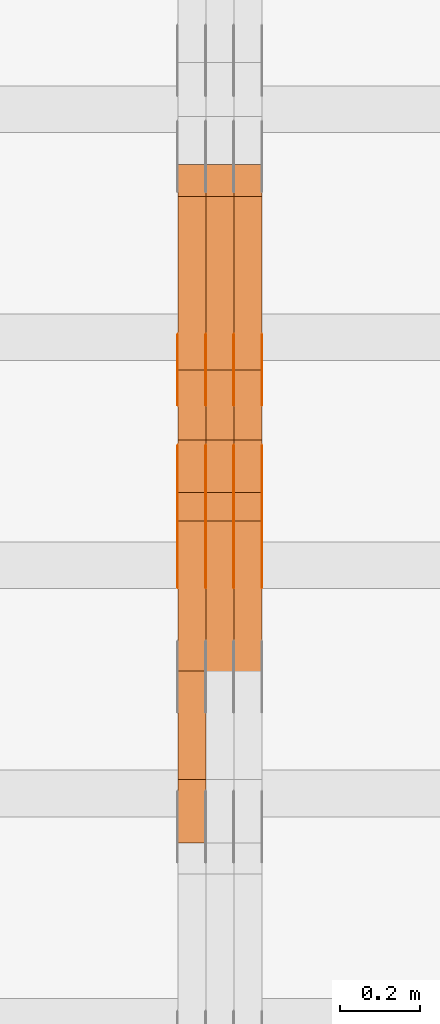
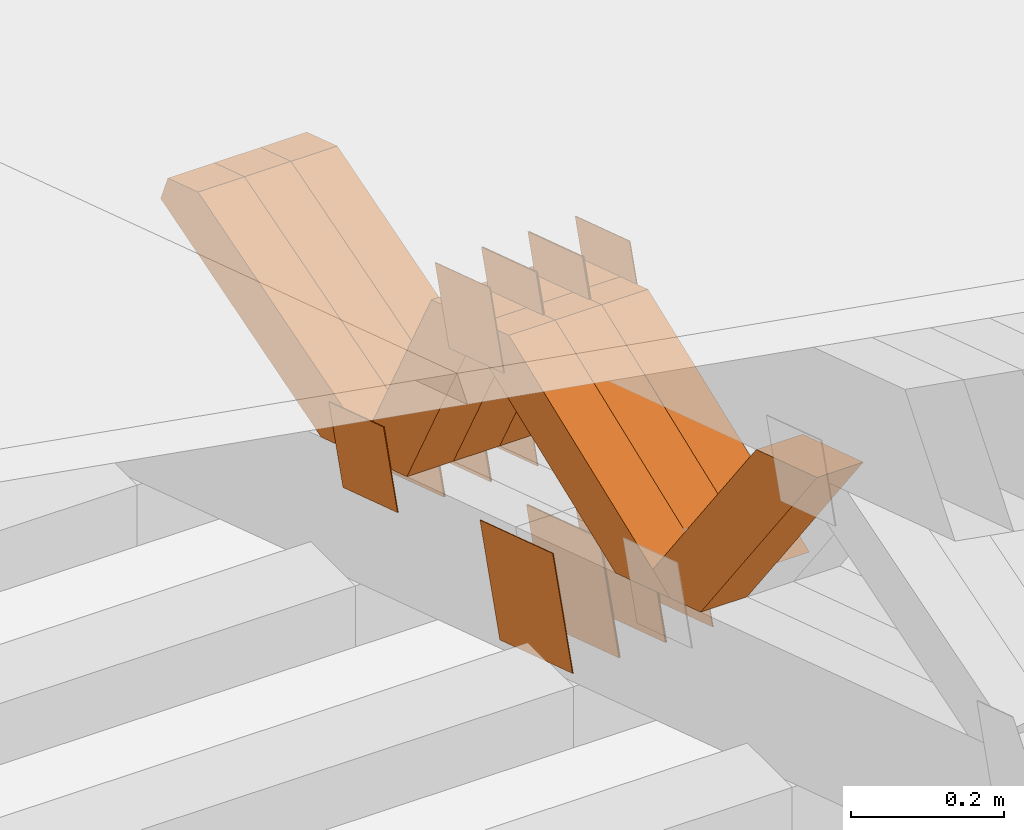
# One storey, part 233 of 385: 28 proxies.
"""IFC2X3 building model written with IfcOpenShell, lengths in millimetres."""

from ifc_helpers import new_model, entity, si_unit, converted_unit, derived_unit, direction, frame, origin, place, context, subcontext, project, spatial, polyline, outline, extrude, source, transform, mapped, material, type_object, type_shapes, element, save


model = new_model("IFC2X3")

# Units and contexts
model_context = context("Model", 3, precision=0.01, world=origin(), true_north=direction((6.12303176911189e-17, 1.0)))
body_context = subcontext(model_context, "Body", "Model", "MODEL_VIEW")
ifc_project = project(units=[si_unit("LENGTHUNIT", "METRE", prefix="MILLI"), si_unit("AREAUNIT", "SQUARE_METRE"), si_unit("VOLUMEUNIT", "CUBIC_METRE"), converted_unit("PLANEANGLEUNIT", "DEGREE", entity("IfcRatioMeasure", 0.0174532925199433), si_unit("PLANEANGLEUNIT", "RADIAN"), dimensions=[0, 0, 0, 0, 0, 0, 0]), si_unit("MASSUNIT", "GRAM", prefix="KILO"), derived_unit("MASSDENSITYUNIT", [(si_unit("MASSUNIT", "GRAM", prefix="KILO"), 1), (si_unit("LENGTHUNIT", "METRE"), -3)]), si_unit("TIMEUNIT", "SECOND"), si_unit("FREQUENCYUNIT", "HERTZ"), si_unit("THERMODYNAMICTEMPERATUREUNIT", "DEGREE_CELSIUS"), derived_unit("THERMALTRANSMITTANCEUNIT", [(si_unit("MASSUNIT", "GRAM", prefix="KILO"), 1), (si_unit("THERMODYNAMICTEMPERATUREUNIT", "KELVIN"), -1), (si_unit("TIMEUNIT", "SECOND"), -3)]), derived_unit("VOLUMETRICFLOWRATEUNIT", [(si_unit("LENGTHUNIT", "METRE"), 3), (si_unit("TIMEUNIT", "SECOND"), -1)]), si_unit("ELECTRICCURRENTUNIT", "AMPERE"), si_unit("ELECTRICVOLTAGEUNIT", "VOLT"), si_unit("POWERUNIT", "WATT"), si_unit("FORCEUNIT", "NEWTON", prefix="KILO"), si_unit("ILLUMINANCEUNIT", "LUX"), si_unit("LUMINOUSFLUXUNIT", "LUMEN"), si_unit("LUMINOUSINTENSITYUNIT", "CANDELA"), derived_unit("USERDEFINED", [(si_unit("MASSUNIT", "GRAM", prefix="KILO"), -1), (si_unit("LENGTHUNIT", "METRE"), -2), (si_unit("TIMEUNIT", "SECOND"), 3), (si_unit("LUMINOUSFLUXUNIT", "LUMEN"), 1)]), derived_unit("LINEARVELOCITYUNIT", [(si_unit("LENGTHUNIT", "METRE"), 1), (si_unit("TIMEUNIT", "SECOND"), -1)]), si_unit("PRESSUREUNIT", "PASCAL"), derived_unit("USERDEFINED", [(si_unit("LENGTHUNIT", "METRE"), -2), (si_unit("MASSUNIT", "GRAM", prefix="KILO"), 1), (si_unit("TIMEUNIT", "SECOND"), -2)])], contexts=[model_context])

# Site, building, storey
site_placement = place(None, origin())
site = spatial("IfcSite", under=ifc_project, at=site_placement, CompositionType="ELEMENT")
building_placement = place(site_placement, origin())
building = spatial("IfcBuilding", under=site, at=building_placement, CompositionType="ELEMENT")
storey_placement = place(building_placement, origin())
storey = spatial("IfcBuildingStorey", under=building, at=storey_placement, Name="Default", CompositionType="ELEMENT", Elevation=0.0)

# Proxies
ifc_material_1 = material(Name="IfcSurfaceStyle #378564")
building_element_proxy_type_1 = type_object("IfcBuildingElementProxyType", PredefinedType="NOTDEFINED", material=ifc_material_1)
shared_shape_1 = source(origin(), body_context, "Body", "SweptSolid", [
    extrude(outline(polyline([(-74.9998794200123, -59.999984515643), (74.9998565677174, -59.999984515643), (74.9998794200123, 59.999984515643), (-74.9998565677174, 59.999984515643), (-74.9998794200123, -59.999984515643)])), frame((75.0000769557496, 60.0000596852268, 0.0), z_axis=(0.0, 0.0, 1.0), x_axis=(-1.0, 0.0, 0.0)), (0.0, 0.0, 1.0), 1.3),
])
type_shapes(building_element_proxy_type_1, [shared_shape_1])
proxy_1_placement = place(building_placement, frame((30386.3, 22649.3668870864, 1282.62115477841), z_axis=(-1.0, 0.0, 0.0), x_axis=(0.0, -0.951056516295124, 0.309016994375039)))
element("IfcBuildingElementProxy", 1, at=proxy_1_placement, inside=storey, type_object=building_element_proxy_type_1, material=ifc_material_1, context=body_context, shape_type="MappedRepresentation", body=[
    mapped(shared_shape_1, transform((0.0, 0.0, 0.0), scale=1.0)),
])
ifc_material_2 = material(Name="IfcSurfaceStyle #378507")
building_element_proxy_type_2 = type_object("IfcBuildingElementProxyType", PredefinedType="NOTDEFINED", material=ifc_material_2)
shared_shape_2 = source(origin(), body_context, "Body", "SweptSolid", [
    extrude(outline(polyline([(-74.9998794200123, -59.999984515643), (74.9998565677174, -59.999984515643), (74.9998794200123, 59.999984515643), (-74.9998565677174, 59.999984515643), (-74.9998794200123, -59.999984515643)])), frame((75.0000769557496, 60.0000596852268, 0.0), z_axis=(0.0, 0.0, 1.0), x_axis=(-1.0, 0.0, 0.0)), (0.0, 0.0, 1.0), 1.3),
])
type_shapes(building_element_proxy_type_2, [shared_shape_2])
proxy_2_placement = place(building_placement, frame((30315.0, 22649.3668870864, 1282.62115477841), z_axis=(-1.0, 0.0, 0.0), x_axis=(0.0, -0.951056516295124, 0.309016994375039)))
element("IfcBuildingElementProxy", 2, at=proxy_2_placement, inside=storey, type_object=building_element_proxy_type_2, material=ifc_material_2, context=body_context, shape_type="MappedRepresentation", body=[
    mapped(shared_shape_2, transform((0.0, 0.0, 0.0), scale=1.0)),
])
ifc_material_3 = material(Name="IfcSurfaceStyle #378450")
building_element_proxy_type_3 = type_object("IfcBuildingElementProxyType", PredefinedType="NOTDEFINED", material=ifc_material_3)
shared_shape_3 = source(origin(), body_context, "Body", "SweptSolid", [
    extrude(outline(polyline([(-74.9998794200123, -59.999984515643), (74.9998565677174, -59.999984515643), (74.9998794200123, 59.999984515643), (-74.9998565677174, 59.999984515643), (-74.9998794200123, -59.999984515643)])), frame((75.0000769557496, 60.0000596852268, 0.0), z_axis=(0.0, 0.0, 1.0), x_axis=(-1.0, 0.0, 0.0)), (0.0, 0.0, 1.0), 1.3),
])
type_shapes(building_element_proxy_type_3, [shared_shape_3])
proxy_3_placement = place(building_placement, frame((30316.3, 22649.3668870864, 1282.62115477841), z_axis=(-1.0, 0.0, 0.0), x_axis=(0.0, -0.951056516295124, 0.309016994375039)))
element("IfcBuildingElementProxy", 3, at=proxy_3_placement, inside=storey, type_object=building_element_proxy_type_3, material=ifc_material_3, context=body_context, shape_type="MappedRepresentation", body=[
    mapped(shared_shape_3, transform((0.0, 0.0, 0.0), scale=1.0)),
])
ifc_material_4 = material(Name="IfcSurfaceStyle #378393")
building_element_proxy_type_4 = type_object("IfcBuildingElementProxyType", PredefinedType="NOTDEFINED", material=ifc_material_4)
shared_shape_4 = source(origin(), body_context, "Body", "SweptSolid", [
    extrude(outline(polyline([(-74.9998794200123, -59.999984515643), (74.9998565677174, -59.999984515643), (74.9998794200123, 59.999984515643), (-74.9998565677174, 59.999984515643), (-74.9998794200123, -59.999984515643)])), frame((75.0000769557496, 60.0000596852268, 0.0), z_axis=(0.0, 0.0, 1.0), x_axis=(-1.0, 0.0, 0.0)), (0.0, 0.0, 1.0), 1.29999999999999),
])
type_shapes(building_element_proxy_type_4, [shared_shape_4])
proxy_4_placement = place(building_placement, frame((30245.0, 22649.3668870864, 1282.62115477841), z_axis=(-1.0, 0.0, 0.0), x_axis=(0.0, -0.951056516295124, 0.309016994375039)))
element("IfcBuildingElementProxy", 4, at=proxy_4_placement, inside=storey, type_object=building_element_proxy_type_4, material=ifc_material_4, context=body_context, shape_type="MappedRepresentation", body=[
    mapped(shared_shape_4, transform((0.0, 0.0, 0.0), scale=1.0)),
])
ifc_material_5 = material(Name="IfcSurfaceStyle #378336")
building_element_proxy_type_5 = type_object("IfcBuildingElementProxyType", PredefinedType="NOTDEFINED", material=ifc_material_5)
shared_shape_5 = source(origin(), body_context, "Body", "SweptSolid", [
    extrude(outline(polyline([(-74.9998794200123, -59.999984515643), (74.9998565677174, -59.999984515643), (74.9998794200123, 59.999984515643), (-74.9998565677174, 59.999984515643), (-74.9998794200123, -59.999984515643)])), frame((75.0000769557496, 60.0000596852268, 0.0), z_axis=(0.0, 0.0, 1.0), x_axis=(-1.0, 0.0, 0.0)), (0.0, 0.0, 1.0), 1.29999999999999),
])
type_shapes(building_element_proxy_type_5, [shared_shape_5])
proxy_5_placement = place(building_placement, frame((30246.3, 22649.3668870864, 1282.62115477841), z_axis=(-1.0, 0.0, 0.0), x_axis=(0.0, -0.951056516295124, 0.309016994375039)))
element("IfcBuildingElementProxy", 5, at=proxy_5_placement, inside=storey, type_object=building_element_proxy_type_5, material=ifc_material_5, context=body_context, shape_type="MappedRepresentation", body=[
    mapped(shared_shape_5, transform((0.0, 0.0, 0.0), scale=1.0)),
])
ifc_material_6 = material(Name="IfcSurfaceStyle #378279")
building_element_proxy_type_6 = type_object("IfcBuildingElementProxyType", PredefinedType="NOTDEFINED", material=ifc_material_6)
shared_shape_6 = source(origin(), body_context, "Body", "SweptSolid", [
    extrude(outline(polyline([(-74.9998794200123, -59.999984515643), (74.9998565677174, -59.999984515643), (74.9998794200123, 59.999984515643), (-74.9998565677174, 59.999984515643), (-74.9998794200123, -59.999984515643)])), frame((75.0000769557496, 60.0000596852268, 0.0), z_axis=(0.0, 0.0, 1.0), x_axis=(-1.0, 0.0, 0.0)), (0.0, 0.0, 1.0), 1.29999999999999),
])
type_shapes(building_element_proxy_type_6, [shared_shape_6])
proxy_6_placement = place(building_placement, frame((30175.0, 22649.3668870864, 1282.62115477841), z_axis=(-1.0, 0.0, 0.0), x_axis=(0.0, -0.951056516295124, 0.309016994375039)))
element("IfcBuildingElementProxy", 6, at=proxy_6_placement, inside=storey, type_object=building_element_proxy_type_6, material=ifc_material_6, context=body_context, shape_type="MappedRepresentation", body=[
    mapped(shared_shape_6, transform((0.0, 0.0, 0.0), scale=1.0)),
])
ifc_material_7 = material(Name="IfcSurfaceStyle #377880")
building_element_proxy_type_7 = type_object("IfcBuildingElementProxyType", PredefinedType="NOTDEFINED", material=ifc_material_7)
shared_shape_7 = source(origin(), body_context, "Body", "SweptSolid", [
    extrude(outline(polyline([(-99.9999579276585, -84.0000593595837), (100.000141865112, -84.0000593595837), (99.9999579276589, 84.0000593595837), (-100.000141865112, 84.0000593595837), (-99.9999579276585, -84.0000593595837)])), frame((100.000141865112, 84.0000593595837, 0.0), z_axis=(0.0, 0.0, 1.0), x_axis=(-1.0, 0.0, 0.0)), (0.0, 0.0, 1.0), 1.3),
])
type_shapes(building_element_proxy_type_7, [shared_shape_7])
proxy_7_placement = place(building_placement, frame((30386.3, 22239.7296395088, 1287.96775368191), z_axis=(-1.0, 0.0, 0.0), x_axis=(0.0, -0.951056516295124, 0.309016994375039)))
element("IfcBuildingElementProxy", 7, at=proxy_7_placement, inside=storey, type_object=building_element_proxy_type_7, material=ifc_material_7, context=body_context, shape_type="MappedRepresentation", body=[
    mapped(shared_shape_7, transform((0.0, 0.0, 0.0), scale=1.0)),
])
ifc_material_8 = material(Name="IfcSurfaceStyle #377823")
building_element_proxy_type_8 = type_object("IfcBuildingElementProxyType", PredefinedType="NOTDEFINED", material=ifc_material_8)
shared_shape_8 = source(origin(), body_context, "Body", "SweptSolid", [
    extrude(outline(polyline([(-99.9999579276585, -84.0000593595837), (100.000141865112, -84.0000593595837), (99.9999579276589, 84.0000593595837), (-100.000141865112, 84.0000593595837), (-99.9999579276585, -84.0000593595837)])), frame((100.000141865112, 84.0000593595837, 0.0), z_axis=(0.0, 0.0, 1.0), x_axis=(-1.0, 0.0, 0.0)), (0.0, 0.0, 1.0), 1.3),
])
type_shapes(building_element_proxy_type_8, [shared_shape_8])
proxy_8_placement = place(building_placement, frame((30315.0, 22239.7296395088, 1287.96775368191), z_axis=(-1.0, 0.0, 0.0), x_axis=(0.0, -0.951056516295124, 0.309016994375039)))
element("IfcBuildingElementProxy", 8, at=proxy_8_placement, inside=storey, type_object=building_element_proxy_type_8, material=ifc_material_8, context=body_context, shape_type="MappedRepresentation", body=[
    mapped(shared_shape_8, transform((0.0, 0.0, 0.0), scale=1.0)),
])
ifc_material_9 = material(Name="IfcSurfaceStyle #377766")
building_element_proxy_type_9 = type_object("IfcBuildingElementProxyType", PredefinedType="NOTDEFINED", material=ifc_material_9)
shared_shape_9 = source(origin(), body_context, "Body", "SweptSolid", [
    extrude(outline(polyline([(-99.9999579276585, -84.0000593595837), (100.000141865112, -84.0000593595837), (99.9999579276589, 84.0000593595837), (-100.000141865112, 84.0000593595837), (-99.9999579276585, -84.0000593595837)])), frame((100.000141865112, 84.0000593595837, 0.0), z_axis=(0.0, 0.0, 1.0), x_axis=(-1.0, 0.0, 0.0)), (0.0, 0.0, 1.0), 1.3),
])
type_shapes(building_element_proxy_type_9, [shared_shape_9])
proxy_9_placement = place(building_placement, frame((30316.3, 22239.7296395088, 1287.96775368191), z_axis=(-1.0, 0.0, 0.0), x_axis=(0.0, -0.951056516295124, 0.309016994375039)))
element("IfcBuildingElementProxy", 9, at=proxy_9_placement, inside=storey, type_object=building_element_proxy_type_9, material=ifc_material_9, context=body_context, shape_type="MappedRepresentation", body=[
    mapped(shared_shape_9, transform((0.0, 0.0, 0.0), scale=1.0)),
])
ifc_material_10 = material(Name="IfcSurfaceStyle #377709")
building_element_proxy_type_10 = type_object("IfcBuildingElementProxyType", PredefinedType="NOTDEFINED", material=ifc_material_10)
shared_shape_10 = source(origin(), body_context, "Body", "SweptSolid", [
    extrude(outline(polyline([(-99.9999579276585, -84.0000593595837), (100.000141865112, -84.0000593595837), (99.9999579276589, 84.0000593595837), (-100.000141865112, 84.0000593595837), (-99.9999579276585, -84.0000593595837)])), frame((100.000141865112, 84.0000593595837, 0.0), z_axis=(0.0, 0.0, 1.0), x_axis=(-1.0, 0.0, 0.0)), (0.0, 0.0, 1.0), 1.29999999999998),
])
type_shapes(building_element_proxy_type_10, [shared_shape_10])
proxy_10_placement = place(building_placement, frame((30245.0, 22239.7296395088, 1287.96775368191), z_axis=(-1.0, 0.0, 0.0), x_axis=(0.0, -0.951056516295124, 0.309016994375039)))
element("IfcBuildingElementProxy", 10, at=proxy_10_placement, inside=storey, type_object=building_element_proxy_type_10, material=ifc_material_10, context=body_context, shape_type="MappedRepresentation", body=[
    mapped(shared_shape_10, transform((0.0, 0.0, 0.0), scale=1.0)),
])
ifc_material_11 = material(Name="IfcSurfaceStyle #377652")
building_element_proxy_type_11 = type_object("IfcBuildingElementProxyType", PredefinedType="NOTDEFINED", material=ifc_material_11)
shared_shape_11 = source(origin(), body_context, "Body", "SweptSolid", [
    extrude(outline(polyline([(-99.9999579276585, -84.0000593595837), (100.000141865112, -84.0000593595837), (99.9999579276589, 84.0000593595837), (-100.000141865112, 84.0000593595837), (-99.9999579276585, -84.0000593595837)])), frame((100.000141865112, 84.0000593595837, 0.0), z_axis=(0.0, 0.0, 1.0), x_axis=(-1.0, 0.0, 0.0)), (0.0, 0.0, 1.0), 1.29999999999998),
])
type_shapes(building_element_proxy_type_11, [shared_shape_11])
proxy_11_placement = place(building_placement, frame((30246.3, 22239.7296395088, 1287.96775368191), z_axis=(-1.0, 0.0, 0.0), x_axis=(0.0, -0.951056516295124, 0.309016994375039)))
element("IfcBuildingElementProxy", 11, at=proxy_11_placement, inside=storey, type_object=building_element_proxy_type_11, material=ifc_material_11, context=body_context, shape_type="MappedRepresentation", body=[
    mapped(shared_shape_11, transform((0.0, 0.0, 0.0), scale=1.0)),
])
ifc_material_12 = material(Name="IfcSurfaceStyle #377595")
building_element_proxy_type_12 = type_object("IfcBuildingElementProxyType", PredefinedType="NOTDEFINED", material=ifc_material_12)
shared_shape_12 = source(origin(), body_context, "Body", "SweptSolid", [
    extrude(outline(polyline([(-99.9999579276585, -84.0000593595837), (100.000141865112, -84.0000593595837), (99.9999579276589, 84.0000593595837), (-100.000141865112, 84.0000593595837), (-99.9999579276585, -84.0000593595837)])), frame((100.000141865112, 84.0000593595837, 0.0), z_axis=(0.0, 0.0, 1.0), x_axis=(-1.0, 0.0, 0.0)), (0.0, 0.0, 1.0), 1.29999999999999),
])
type_shapes(building_element_proxy_type_12, [shared_shape_12])
proxy_12_placement = place(building_placement, frame((30175.0, 22239.7296395088, 1287.96775368191), z_axis=(-1.0, 0.0, 0.0), x_axis=(0.0, -0.951056516295124, 0.309016994375039)))
element("IfcBuildingElementProxy", 12, at=proxy_12_placement, inside=storey, type_object=building_element_proxy_type_12, material=ifc_material_12, context=body_context, shape_type="MappedRepresentation", body=[
    mapped(shared_shape_12, transform((0.0, 0.0, 0.0), scale=1.0)),
])
ifc_material_13 = material(Name="IfcSurfaceStyle #369330")
building_element_proxy_type_13 = type_object("IfcBuildingElementProxyType", PredefinedType="NOTDEFINED", material=ifc_material_13)
shared_shape_13 = source(origin(), body_context, "Body", "SweptSolid", [
    extrude(outline(polyline([(-74.9998794200069, -59.9999845156358), (74.9998565677229, -59.9999845156358), (74.9998794200069, 59.9999845156358), (-74.9998565677229, 59.9999845156358), (-74.9998794200069, -59.9999845156358)])), frame((75.0000966453795, 60.0000596852335, 0.0), z_axis=(0.0, 0.0, 1.0), x_axis=(-1.0, 0.0, 0.0)), (0.0, 0.0, 1.0), 1.3),
])
type_shapes(building_element_proxy_type_13, [shared_shape_13])
proxy_13_placement = place(building_placement, frame((30386.3, 22372.1881948749, 1673.08440552992), z_axis=(-1.0, 0.0, 0.0), x_axis=(0.0, -0.951056516295154, 0.309016994374948)))
element("IfcBuildingElementProxy", 13, at=proxy_13_placement, inside=storey, type_object=building_element_proxy_type_13, material=ifc_material_13, context=body_context, shape_type="MappedRepresentation", body=[
    mapped(shared_shape_13, transform((0.0, 0.0, 0.0), scale=1.0)),
])
ifc_material_14 = material(Name="IfcSurfaceStyle #369273")
building_element_proxy_type_14 = type_object("IfcBuildingElementProxyType", PredefinedType="NOTDEFINED", material=ifc_material_14)
shared_shape_14 = source(origin(), body_context, "Body", "SweptSolid", [
    extrude(outline(polyline([(-74.9998794200069, -59.9999845156358), (74.9998565677229, -59.9999845156358), (74.9998794200069, 59.9999845156358), (-74.9998565677229, 59.9999845156358), (-74.9998794200069, -59.9999845156358)])), frame((75.0000966453795, 60.0000596852335, 0.0), z_axis=(0.0, 0.0, 1.0), x_axis=(-1.0, 0.0, 0.0)), (0.0, 0.0, 1.0), 1.3),
])
type_shapes(building_element_proxy_type_14, [shared_shape_14])
proxy_14_placement = place(building_placement, frame((30315.0, 22372.1881948749, 1673.08440552992), z_axis=(-1.0, 0.0, 0.0), x_axis=(0.0, -0.951056516295154, 0.309016994374948)))
element("IfcBuildingElementProxy", 14, at=proxy_14_placement, inside=storey, type_object=building_element_proxy_type_14, material=ifc_material_14, context=body_context, shape_type="MappedRepresentation", body=[
    mapped(shared_shape_14, transform((0.0, 0.0, 0.0), scale=1.0)),
])
ifc_material_15 = material(Name="IfcSurfaceStyle #369216")
building_element_proxy_type_15 = type_object("IfcBuildingElementProxyType", PredefinedType="NOTDEFINED", material=ifc_material_15)
shared_shape_15 = source(origin(), body_context, "Body", "SweptSolid", [
    extrude(outline(polyline([(-74.9998794200069, -59.9999845156358), (74.9998565677229, -59.9999845156358), (74.9998794200069, 59.9999845156358), (-74.9998565677229, 59.9999845156358), (-74.9998794200069, -59.9999845156358)])), frame((75.0000966453795, 60.0000596852335, 0.0), z_axis=(0.0, 0.0, 1.0), x_axis=(-1.0, 0.0, 0.0)), (0.0, 0.0, 1.0), 1.3),
])
type_shapes(building_element_proxy_type_15, [shared_shape_15])
proxy_15_placement = place(building_placement, frame((30316.3, 22372.1881948749, 1673.08440552992), z_axis=(-1.0, 0.0, 0.0), x_axis=(0.0, -0.951056516295154, 0.309016994374948)))
element("IfcBuildingElementProxy", 15, at=proxy_15_placement, inside=storey, type_object=building_element_proxy_type_15, material=ifc_material_15, context=body_context, shape_type="MappedRepresentation", body=[
    mapped(shared_shape_15, transform((0.0, 0.0, 0.0), scale=1.0)),
])
ifc_material_16 = material(Name="IfcSurfaceStyle #369159")
building_element_proxy_type_16 = type_object("IfcBuildingElementProxyType", PredefinedType="NOTDEFINED", material=ifc_material_16)
shared_shape_16 = source(origin(), body_context, "Body", "SweptSolid", [
    extrude(outline(polyline([(-74.9998794200069, -59.9999845156358), (74.9998565677229, -59.9999845156358), (74.9998794200069, 59.9999845156358), (-74.9998565677229, 59.9999845156358), (-74.9998794200069, -59.9999845156358)])), frame((75.0000966453795, 60.0000596852335, 0.0), z_axis=(0.0, 0.0, 1.0), x_axis=(-1.0, 0.0, 0.0)), (0.0, 0.0, 1.0), 1.29999999999999),
])
type_shapes(building_element_proxy_type_16, [shared_shape_16])
proxy_16_placement = place(building_placement, frame((30245.0, 22372.1881948749, 1673.08440552992), z_axis=(-1.0, 0.0, 0.0), x_axis=(0.0, -0.951056516295154, 0.309016994374948)))
element("IfcBuildingElementProxy", 16, at=proxy_16_placement, inside=storey, type_object=building_element_proxy_type_16, material=ifc_material_16, context=body_context, shape_type="MappedRepresentation", body=[
    mapped(shared_shape_16, transform((0.0, 0.0, 0.0), scale=1.0)),
])
ifc_material_17 = material(Name="IfcSurfaceStyle #369102")
building_element_proxy_type_17 = type_object("IfcBuildingElementProxyType", PredefinedType="NOTDEFINED", material=ifc_material_17)
shared_shape_17 = source(origin(), body_context, "Body", "SweptSolid", [
    extrude(outline(polyline([(-74.9998794200069, -59.9999845156358), (74.9998565677229, -59.9999845156358), (74.9998794200069, 59.9999845156358), (-74.9998565677229, 59.9999845156358), (-74.9998794200069, -59.9999845156358)])), frame((75.0000966453795, 60.0000596852335, 0.0), z_axis=(0.0, 0.0, 1.0), x_axis=(-1.0, 0.0, 0.0)), (0.0, 0.0, 1.0), 1.29999999999999),
])
type_shapes(building_element_proxy_type_17, [shared_shape_17])
proxy_17_placement = place(building_placement, frame((30246.3, 22372.1881948749, 1673.08440552992), z_axis=(-1.0, 0.0, 0.0), x_axis=(0.0, -0.951056516295154, 0.309016994374948)))
element("IfcBuildingElementProxy", 17, at=proxy_17_placement, inside=storey, type_object=building_element_proxy_type_17, material=ifc_material_17, context=body_context, shape_type="MappedRepresentation", body=[
    mapped(shared_shape_17, transform((0.0, 0.0, 0.0), scale=1.0)),
])
ifc_material_18 = material(Name="IfcSurfaceStyle #369045")
building_element_proxy_type_18 = type_object("IfcBuildingElementProxyType", PredefinedType="NOTDEFINED", material=ifc_material_18)
shared_shape_18 = source(origin(), body_context, "Body", "SweptSolid", [
    extrude(outline(polyline([(-74.9998794200069, -59.9999845156358), (74.9998565677229, -59.9999845156358), (74.9998794200069, 59.9999845156358), (-74.9998565677229, 59.9999845156358), (-74.9998794200069, -59.9999845156358)])), frame((75.0000966453795, 60.0000596852335, 0.0), z_axis=(0.0, 0.0, 1.0), x_axis=(-1.0, 0.0, 0.0)), (0.0, 0.0, 1.0), 1.29999999999999),
])
type_shapes(building_element_proxy_type_18, [shared_shape_18])
proxy_18_placement = place(building_placement, frame((30175.0, 22372.1881948749, 1673.08440552992), z_axis=(-1.0, 0.0, 0.0), x_axis=(0.0, -0.951056516295154, 0.309016994374948)))
element("IfcBuildingElementProxy", 18, at=proxy_18_placement, inside=storey, type_object=building_element_proxy_type_18, material=ifc_material_18, context=body_context, shape_type="MappedRepresentation", body=[
    mapped(shared_shape_18, transform((0.0, 0.0, 0.0), scale=1.0)),
])
ifc_material_19 = material(Name="IfcSurfaceStyle #357246")
building_element_proxy_type_19 = type_object("IfcBuildingElementProxyType", Name="T1-W18 357244", PredefinedType="NOTDEFINED", material=ifc_material_19)
shared_shape_19 = source(origin(), body_context, "Body", "SweptSolid", [
    extrude(outline(polyline([(-221.504996322134, -47.4999929258616), (225.406467948779, -47.4999929258616), (211.663832468686, -0.000107703153482008), (143.08905281687, 47.5000467774384), (-358.6543569122, 47.5000467774384), (-221.504996322134, -47.4999929258616)])), frame((225.406576158364, 47.5000467774384, 0.0), z_axis=(0.0, 0.0, 1.0), x_axis=(-1.0, 0.0, 0.0)), (0.0, 0.0, 1.0), 70.0),
])
type_shapes(building_element_proxy_type_19, [shared_shape_19])
proxy_19_placement = place(building_placement, frame((30245.0, 21766.9513837803, 1583.13813361817), z_axis=(-1.0, 0.0, 0.0), x_axis=(0.0, -0.605858491298265, 0.795572428206126)))
element("IfcBuildingElementProxy", 19, at=proxy_19_placement, inside=storey, type_object=building_element_proxy_type_19, material=ifc_material_19, Name="T1-W18", context=body_context, shape_type="MappedRepresentation", body=[
    mapped(shared_shape_19, transform((0.0, 0.0, 0.0), scale=1.0)),
])
ifc_material_20 = material(Name="IfcSurfaceStyle #356982")
building_element_proxy_type_20 = type_object("IfcBuildingElementProxyType", Name="T1-W30 356980", PredefinedType="NOTDEFINED", material=ifc_material_20)
shared_shape_20 = source(origin(), body_context, "Body", "SweptSolid", [
    extrude(outline(polyline([(-319.322304176575, -47.5000259045904), (133.154090927094, -47.5000259045904), (191.489196707701, 6.99403755251016e-06), (197.330697834052, 47.5000224075717), (-202.651681292271, 47.5000224075717), (-319.322304176575, -47.5000259045904)])), frame((197.330834478517, 47.5000608592405, 0.0), z_axis=(0.0, 0.0, 1.0), x_axis=(-1.0, 0.0, 0.0)), (0.0, 0.0, 1.0), 70.0),
])
type_shapes(building_element_proxy_type_20, [shared_shape_20])
proxy_20_placement = place(building_placement, frame((30385.0, 22312.5352975627, 1720.70362673362), z_axis=(-1.0, 0.0, 0.0), x_axis=(0.0, -0.932610696879359, -0.360884036868072)))
element("IfcBuildingElementProxy", 20, at=proxy_20_placement, inside=storey, type_object=building_element_proxy_type_20, material=ifc_material_20, Name="T1-W30", context=body_context, shape_type="MappedRepresentation", body=[
    mapped(shared_shape_20, transform((0.0, 0.0, 0.0), scale=1.0)),
])
ifc_material_21 = material(Name="IfcSurfaceStyle #356916")
building_element_proxy_type_21 = type_object("IfcBuildingElementProxyType", Name="T1-W30 356914", PredefinedType="NOTDEFINED", material=ifc_material_21)
shared_shape_21 = source(origin(), body_context, "Body", "SweptSolid", [
    extrude(outline(polyline([(-319.322304176575, -47.5000259045904), (133.154090927094, -47.5000259045904), (191.489196707701, 6.99403755251016e-06), (197.330697834052, 47.5000224075717), (-202.651681292271, 47.5000224075717), (-319.322304176575, -47.5000259045904)])), frame((197.330834478517, 47.5000608592405, 0.0), z_axis=(0.0, 0.0, 1.0), x_axis=(-1.0, 0.0, 0.0)), (0.0, 0.0, 1.0), 70.0),
])
type_shapes(building_element_proxy_type_21, [shared_shape_21])
proxy_21_placement = place(building_placement, frame((30315.0, 22312.5352975627, 1720.70362673362), z_axis=(-1.0, 0.0, 0.0), x_axis=(0.0, -0.932610696879359, -0.360884036868072)))
element("IfcBuildingElementProxy", 21, at=proxy_21_placement, inside=storey, type_object=building_element_proxy_type_21, material=ifc_material_21, Name="T1-W30", context=body_context, shape_type="MappedRepresentation", body=[
    mapped(shared_shape_21, transform((0.0, 0.0, 0.0), scale=1.0)),
])
ifc_material_22 = material(Name="IfcSurfaceStyle #356850")
building_element_proxy_type_22 = type_object("IfcBuildingElementProxyType", Name="T1-W30 356848", PredefinedType="NOTDEFINED", material=ifc_material_22)
shared_shape_22 = source(origin(), body_context, "Body", "SweptSolid", [
    extrude(outline(polyline([(-319.322304176575, -47.5000259045904), (133.154090927094, -47.5000259045904), (191.489196707701, 6.99403755251016e-06), (197.330697834052, 47.5000224075717), (-202.651681292271, 47.5000224075717), (-319.322304176575, -47.5000259045904)])), frame((197.330834478517, 47.5000608592405, 0.0), z_axis=(0.0, 0.0, 1.0), x_axis=(-1.0, 0.0, 0.0)), (0.0, 0.0, 1.0), 70.0),
])
type_shapes(building_element_proxy_type_22, [shared_shape_22])
proxy_22_placement = place(building_placement, frame((30245.0, 22312.5352975627, 1720.70362673362), z_axis=(-1.0, 0.0, 0.0), x_axis=(0.0, -0.932610696879359, -0.360884036868072)))
element("IfcBuildingElementProxy", 22, at=proxy_22_placement, inside=storey, type_object=building_element_proxy_type_22, material=ifc_material_22, Name="T1-W30", context=body_context, shape_type="MappedRepresentation", body=[
    mapped(shared_shape_22, transform((0.0, 0.0, 0.0), scale=1.0)),
])
ifc_material_23 = material(Name="IfcSurfaceStyle #356586")
building_element_proxy_type_23 = type_object("IfcBuildingElementProxyType", Name="T1-W41 356584", PredefinedType="NOTDEFINED", material=ifc_material_23)
shared_shape_23 = source(origin(), body_context, "Body", "SweptSolid", [
    extrude(outline(polyline([(-190.064783497519, -47.5001011048749), (182.590736871656, -47.5001011048749), (172.978793750747, 0.000111395300689243), (123.505951450908, 47.5000454072246), (-289.010698575792, 47.5000454072246), (-190.064783497519, -47.5001011048749)])), frame((182.590736871656, 47.5001973817447, 0.0), z_axis=(0.0, 0.0, 1.0), x_axis=(-1.0, 0.0, 0.0)), (0.0, 0.0, 1.0), 70.0),
])
type_shapes(building_element_proxy_type_23, [shared_shape_23])
proxy_23_placement = place(building_placement, frame((30385.0, 22512.5506969063, 1347.13648051689), z_axis=(-1.0, 0.0, 0.0), x_axis=(0.0, -0.472020158706979, 0.881587755004706)))
element("IfcBuildingElementProxy", 23, at=proxy_23_placement, inside=storey, type_object=building_element_proxy_type_23, material=ifc_material_23, Name="T1-W41", context=body_context, shape_type="MappedRepresentation", body=[
    mapped(shared_shape_23, transform((0.0, 0.0, 0.0), scale=1.0)),
])
ifc_material_24 = material(Name="IfcSurfaceStyle #356520")
building_element_proxy_type_24 = type_object("IfcBuildingElementProxyType", Name="T1-W41 356518", PredefinedType="NOTDEFINED", material=ifc_material_24)
shared_shape_24 = source(origin(), body_context, "Body", "SweptSolid", [
    extrude(outline(polyline([(-190.064783497519, -47.5001011048749), (182.590736871656, -47.5001011048749), (172.978793750747, 0.000111395300689243), (123.505951450908, 47.5000454072246), (-289.010698575792, 47.5000454072246), (-190.064783497519, -47.5001011048749)])), frame((182.590736871656, 47.5001973817447, 0.0), z_axis=(0.0, 0.0, 1.0), x_axis=(-1.0, 0.0, 0.0)), (0.0, 0.0, 1.0), 70.0),
])
type_shapes(building_element_proxy_type_24, [shared_shape_24])
proxy_24_placement = place(building_placement, frame((30315.0, 22512.5506969063, 1347.13648051689), z_axis=(-1.0, 0.0, 0.0), x_axis=(0.0, -0.472020158706979, 0.881587755004706)))
element("IfcBuildingElementProxy", 24, at=proxy_24_placement, inside=storey, type_object=building_element_proxy_type_24, material=ifc_material_24, Name="T1-W41", context=body_context, shape_type="MappedRepresentation", body=[
    mapped(shared_shape_24, transform((0.0, 0.0, 0.0), scale=1.0)),
])
ifc_material_25 = material(Name="IfcSurfaceStyle #356454")
building_element_proxy_type_25 = type_object("IfcBuildingElementProxyType", Name="T1-W41 356452", PredefinedType="NOTDEFINED", material=ifc_material_25)
shared_shape_25 = source(origin(), body_context, "Body", "SweptSolid", [
    extrude(outline(polyline([(-190.064783497519, -47.5001011048749), (182.590736871656, -47.5001011048749), (172.978793750747, 0.000111395300689243), (123.505951450908, 47.5000454072246), (-289.010698575792, 47.5000454072246), (-190.064783497519, -47.5001011048749)])), frame((182.590736871656, 47.5001973817447, 0.0), z_axis=(0.0, 0.0, 1.0), x_axis=(-1.0, 0.0, 0.0)), (0.0, 0.0, 1.0), 70.0),
])
type_shapes(building_element_proxy_type_25, [shared_shape_25])
proxy_25_placement = place(building_placement, frame((30245.0, 22512.5506969063, 1347.13648051689), z_axis=(-1.0, 0.0, 0.0), x_axis=(0.0, -0.472020158706979, 0.881587755004706)))
element("IfcBuildingElementProxy", 25, at=proxy_25_placement, inside=storey, type_object=building_element_proxy_type_25, material=ifc_material_25, Name="T1-W41", context=body_context, shape_type="MappedRepresentation", body=[
    mapped(shared_shape_25, transform((0.0, 0.0, 0.0), scale=1.0)),
])
ifc_material_26 = material(Name="IfcSurfaceStyle #356190")
building_element_proxy_type_26 = type_object("IfcBuildingElementProxyType", Name="T1-W23 356188", PredefinedType="NOTDEFINED", material=ifc_material_26)
shared_shape_26 = source(origin(), body_context, "Body", "SweptSolid", [
    extrude(outline(polyline([(-356.808656505462, -47.5000180192671), (144.726334557508, -47.5000180192671), (213.258834104997, -2.90494310381195e-05), (218.567145253444, 47.5000325439826), (-219.743657410487, 47.5000325439827), (-356.808656505462, -47.5000180192671)])), frame((218.567145253444, 47.5000325439826, 0.0), z_axis=(0.0, 0.0, 1.0), x_axis=(-1.0, 0.0, 0.0)), (0.0, 0.0, 1.0), 70.0),
])
type_shapes(building_element_proxy_type_26, [shared_shape_26])
proxy_26_placement = place(building_placement, frame((30385.0, 23128.2626953125, 1452.63940429688), z_axis=(-1.0, 0.0, 0.0), x_axis=(0.0, -0.957692700226705, -0.287792793399143)))
element("IfcBuildingElementProxy", 26, at=proxy_26_placement, inside=storey, type_object=building_element_proxy_type_26, material=ifc_material_26, Name="T1-W23", context=body_context, shape_type="MappedRepresentation", body=[
    mapped(shared_shape_26, transform((0.0, 0.0, 0.0), scale=1.0)),
])
ifc_material_27 = material(Name="IfcSurfaceStyle #356124")
building_element_proxy_type_27 = type_object("IfcBuildingElementProxyType", Name="T1-W23 356122", PredefinedType="NOTDEFINED", material=ifc_material_27)
shared_shape_27 = source(origin(), body_context, "Body", "SweptSolid", [
    extrude(outline(polyline([(-356.808656505462, -47.5000180192671), (144.726334557508, -47.5000180192671), (213.258834104997, -2.90494310381195e-05), (218.567145253444, 47.5000325439826), (-219.743657410487, 47.5000325439827), (-356.808656505462, -47.5000180192671)])), frame((218.567145253444, 47.5000325439826, 0.0), z_axis=(0.0, 0.0, 1.0), x_axis=(-1.0, 0.0, 0.0)), (0.0, 0.0, 1.0), 70.0),
])
type_shapes(building_element_proxy_type_27, [shared_shape_27])
proxy_27_placement = place(building_placement, frame((30315.0, 23128.2626953125, 1452.63940429688), z_axis=(-1.0, 0.0, 0.0), x_axis=(0.0, -0.957692700226705, -0.287792793399143)))
element("IfcBuildingElementProxy", 27, at=proxy_27_placement, inside=storey, type_object=building_element_proxy_type_27, material=ifc_material_27, Name="T1-W23", context=body_context, shape_type="MappedRepresentation", body=[
    mapped(shared_shape_27, transform((0.0, 0.0, 0.0), scale=1.0)),
])
ifc_material_28 = material(Name="IfcSurfaceStyle #356058")
building_element_proxy_type_28 = type_object("IfcBuildingElementProxyType", Name="T1-W23 356056", PredefinedType="NOTDEFINED", material=ifc_material_28)
shared_shape_28 = source(origin(), body_context, "Body", "SweptSolid", [
    extrude(outline(polyline([(-356.808656505462, -47.5000180192671), (144.726334557508, -47.5000180192671), (213.258834104997, -2.90494310381195e-05), (218.567145253444, 47.5000325439826), (-219.743657410487, 47.5000325439827), (-356.808656505462, -47.5000180192671)])), frame((218.567145253444, 47.5000325439826, 0.0), z_axis=(0.0, 0.0, 1.0), x_axis=(-1.0, 0.0, 0.0)), (0.0, 0.0, 1.0), 70.0),
])
type_shapes(building_element_proxy_type_28, [shared_shape_28])
proxy_28_placement = place(building_placement, frame((30245.0, 23128.2626953125, 1452.63940429688), z_axis=(-1.0, 0.0, 0.0), x_axis=(0.0, -0.957692700226705, -0.287792793399143)))
element("IfcBuildingElementProxy", 28, at=proxy_28_placement, inside=storey, type_object=building_element_proxy_type_28, material=ifc_material_28, Name="T1-W23", context=body_context, shape_type="MappedRepresentation", body=[
    mapped(shared_shape_28, transform((0.0, 0.0, 0.0), scale=1.0)),
])

save(model, "model.ifc")
